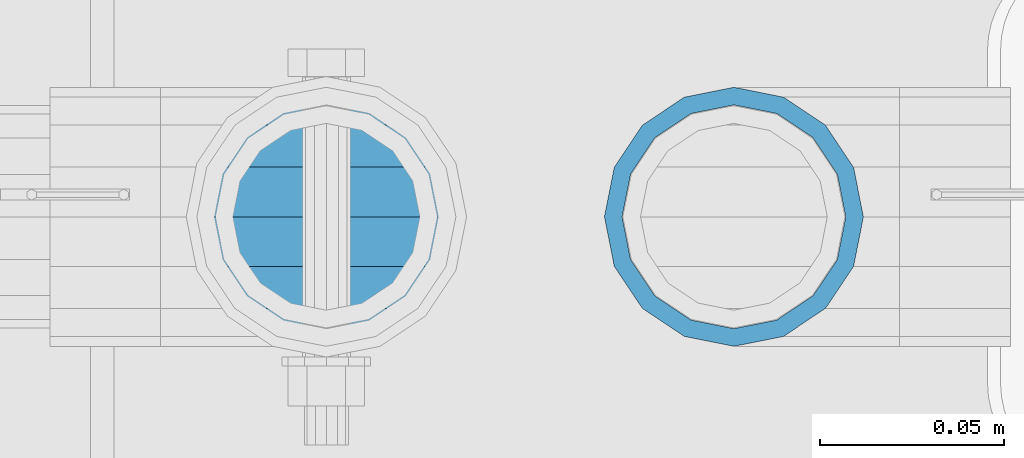
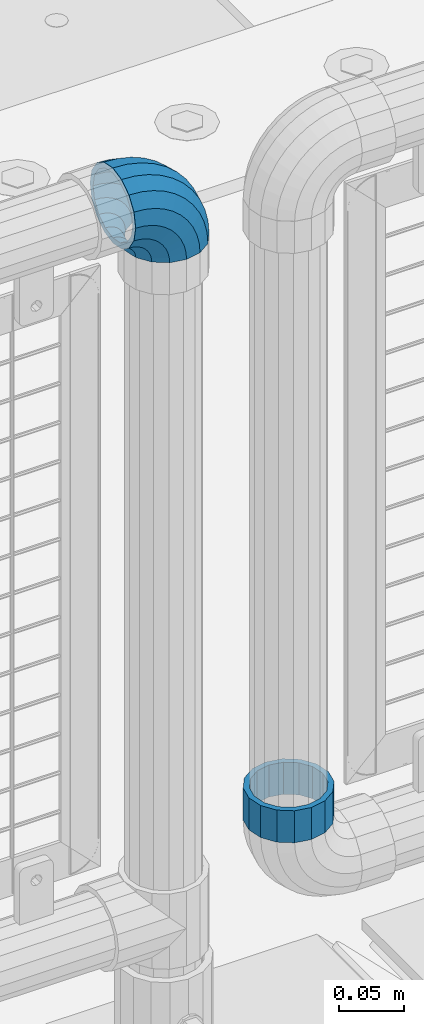
# One storey, part 163 of 242: 1 beam, 1 member.
"""IFC2X3 building model written with IfcOpenShell, lengths in millimetres."""

from ifc_helpers import new_model, si_unit, frame, origin_with_axes, place, context, subcontext, project, spatial, faceted_brep, material, type_object, element, save


model = new_model("IFC2X3")

# Units and contexts
model_context = context("Model", 3, precision=1e-05, world=origin_with_axes())
body_context = subcontext(model_context, "Body", "Model", "MODEL_VIEW")
ifc_project = project(units=[si_unit("LENGTHUNIT", "METRE", prefix="MILLI"), si_unit("AREAUNIT", "SQUARE_METRE"), si_unit("VOLUMEUNIT", "CUBIC_METRE"), si_unit("MASSUNIT", "GRAM", prefix="KILO"), si_unit("TIMEUNIT", "SECOND"), si_unit("PLANEANGLEUNIT", "RADIAN"), si_unit("SOLIDANGLEUNIT", "STERADIAN"), si_unit("THERMODYNAMICTEMPERATUREUNIT", "DEGREE_CELSIUS"), si_unit("LUMINOUSINTENSITYUNIT", "LUMEN")], contexts=[model_context])

# Site, building, storey
site_placement = place(None, origin_with_axes())
site = spatial("IfcSite", under=ifc_project, at=site_placement, CompositionType="ELEMENT")
building_placement = place(site_placement, origin_with_axes())
building = spatial("IfcBuilding", under=site, at=building_placement, Name="Standard", CompositionType="ELEMENT")
storey_placement = place(building_placement, origin_with_axes())
storey = spatial("IfcBuildingStorey", under=building, at=storey_placement, Name="Undefined", CompositionType="ELEMENT", Elevation=0.0)

# Beam
ifc_material = material(Name="Misc_Undefined")
beam_type = type_object("IfcBeamType", PredefinedType="NOTDEFINED")
beam_placement = place(storey_placement, frame((-23755.39, -19335.5, 373.170000000002), z_axis=(-1.0, 0.0, 0.0), x_axis=(0.0, 0.0, -1.0)))
element("IfcBeam", 1, at=beam_placement, inside=storey, type_object=beam_type, material=ifc_material, context=body_context, shape_type="Brep", body=[
    faceted_brep([(0.0, -30.3499999999985, 0.0), (0.0, -28.0397438117179, 11.6144421722784), (30.0, -28.0397438117179, 11.6144421722805), (30.0, -30.3499999999985, 0.0), (0.0, -21.46069080901, 21.4606908090136), (30.0, -21.46069080901, 21.4606908090117), (0.0, -11.614442172282, 28.0397438117143), (30.0, -11.614442172282, 28.0397438117176), (0.0, 0.0, 30.3499999999985), (30.0, 0.0, 30.35), (0.0, 11.614442172282, 28.0397438117143), (30.0, 11.614442172282, 28.0397438117176), (0.0, 21.46069080901, 21.4606908090136), (30.0, 21.46069080901, 21.4606908090117), (0.0, 28.0397438117179, 11.6144421722784), (30.0, 28.0397438117179, 11.6144421722805), (0.0, 30.3499999999985, 0.0), (30.0, 30.3499999999985, 0.0), (0.0, 28.0397438117179, -11.6144421722784), (30.0, 28.0397438117179, -11.6144421722805), (0.0, 21.46069080901, -21.4606908090136), (30.0, 21.46069080901, -21.4606908090117), (0.0, 11.614442172282, -28.0397438117143), (30.0, 11.614442172282, -28.0397438117176), (0.0, 0.0, -30.3499999999985), (30.0, 0.0, -30.35), (0.0, -11.614442172282, -28.0397438117143), (30.0, -11.614442172282, -28.0397438117176), (0.0, -21.46069080901, -21.4606908090136), (30.0, -21.46069080901, -21.4606908090117), (0.0, -28.0397438117179, -11.6144421722784), (30.0, -28.0397438117179, -11.6144421722805), (0.0, -35.1500000000015, 0.0), (0.0, -32.4743655677703, -13.4513226476338), (30.0, -32.4743655677703, -13.4513226476329), (30.0, -35.1500000000015, 0.0), (0.0, -24.8548033587067, -24.8548033587067), (30.0, -24.8548033587067, -24.8548033587072), (0.0, -13.4513226476338, -32.4743655677739), (30.0, -13.4513226476338, -32.4743655677718), (0.0, 0.0, -35.1500000000015), (30.0, 0.0, -35.15), (0.0, 13.4513226476338, -32.4743655677739), (30.0, 13.4513226476338, -32.4743655677718), (0.0, 24.8548033587067, -24.8548033587067), (30.0, 24.8548033587067, -24.8548033587072), (0.0, 32.4743655677703, -13.4513226476338), (30.0, 32.4743655677703, -13.4513226476329), (0.0, 35.1500000000015, 0.0), (30.0, 35.1500000000015, 0.0), (0.0, 32.4743655677703, 13.4513226476338), (30.0, 32.4743655677703, 13.4513226476329), (0.0, 24.8548033587067, 24.8548033587067), (30.0, 24.8548033587067, 24.8548033587072), (0.0, 13.4513226476338, 32.4743655677739), (30.0, 13.4513226476338, 32.4743655677718), (0.0, 0.0, 35.1500000000015), (30.0, 0.0, 35.15), (0.0, -13.4513226476338, 32.4743655677739), (30.0, -13.4513226476338, 32.4743655677718), (0.0, -24.8548033587067, 24.8548033587067), (30.0, -24.8548033587067, 24.8548033587072), (0.0, -32.4743655677703, 13.4513226476338), (30.0, -32.4743655677703, 13.4513226476329)], [[[0, 1, 2, 3]], [[1, 4, 5, 2]], [[4, 6, 7, 5]], [[6, 8, 9, 7]], [[8, 10, 11, 9]], [[10, 12, 13, 11]], [[12, 14, 15, 13]], [[14, 16, 17, 15]], [[16, 18, 19, 17]], [[18, 20, 21, 19]], [[20, 22, 23, 21]], [[22, 24, 25, 23]], [[24, 26, 27, 25]], [[26, 28, 29, 27]], [[28, 30, 31, 29]], [[30, 0, 3, 31]], [[32, 33, 34, 35]], [[33, 36, 37, 34]], [[36, 38, 39, 37]], [[38, 40, 41, 39]], [[40, 42, 43, 41]], [[42, 44, 45, 43]], [[44, 46, 47, 45]], [[46, 48, 49, 47]], [[48, 50, 51, 49]], [[50, 52, 53, 51]], [[52, 54, 55, 53]], [[54, 56, 57, 55]], [[56, 58, 59, 57]], [[58, 60, 61, 59]], [[60, 62, 63, 61]], [[62, 32, 35, 63]], [[37, 39, 41, 43, 45, 47, 49, 51, 53, 55, 57, 59, 61, 63, 35, 34], [5, 7, 9, 11, 13, 15, 17, 19, 21, 23, 25, 27, 29, 31, 3, 2]], [[62, 60, 58, 56, 54, 52, 50, 48, 46, 44, 42, 40, 38, 36, 33, 32], [30, 28, 26, 24, 22, 20, 18, 16, 14, 12, 10, 8, 6, 4, 1, 0]]]),
])

# Member
member_type = type_object("IfcMemberType", PredefinedType="NOTDEFINED")
member_placement = place(storey_placement, frame((-23866.0, -19335.5, 924.85), z_axis=(0.707106781186547, 0.0, 0.707106781186548), x_axis=(-0.707106781186548, 0.0, 0.707106781186548)))
element("IfcMember", 2, at=member_placement, inside=storey, type_object=member_type, material=ifc_material, context=body_context, shape_type="Brep", body=[
    faceted_brep([(0.0, -35.1500000000015, 0.0), (9.51152146006643, -32.4743655677703, -9.51152146006643), (13.2759578763398, -32.4743655677703, -6.29638902527768), (5.36946880023243, -35.1500000000015, 4.58595959347804), (17.5749999999971, -24.8548033587067, -17.5749999999971), (19.978755663109, -24.8548033587067, -15.5219987155633), (22.9628441077002, -13.4513226476338, -22.9628441077002), (24.4574219585229, -13.4513226476338, -21.6863540323939), (24.8548033587067, 0.0, -24.8548033587067), (26.0301204183124, 0.0, -23.8509877588003), (22.9628441077002, 13.4513226476338, -22.9628441077002), (24.4574219585229, 13.4513226476338, -21.6863540323939), (17.5749999999971, 24.8548033587067, -17.5749999999971), (19.978755663109, 24.8548033587067, -15.5219987155633), (9.51152146006643, 32.4743655677703, -9.51152146006643), (13.2759578763398, 32.4743655677703, -6.29638902527768), (0.0, 35.1500000000015, 0.0), (5.36946880023243, 35.1500000000015, 4.58595959347804), (-9.51152146007371, 32.4743655677703, 9.51152146007371), (-2.53702027587133, 32.4743655677703, 15.4683082122338), (-17.5750000000007, 24.8548033587067, 17.5750000000007), (-9.23981806264783, 24.8548033587067, 24.6939179025212), (-22.9628441077039, 13.4513226476338, 22.9628441077039), (-13.718484358058, 13.4513226476338, 30.8582732193499), (-24.8548033587103, 0.0, 24.8548033587103), (-15.2911828178512, 0.0, 33.02290694576), (-22.9628441077039, -13.4513226476338, 22.9628441077039), (-13.718484358058, -13.4513226476338, 30.8582732193499), (-17.5750000000007, -24.8548033587067, 17.5750000000007), (-9.23981806264783, -24.8548033587067, 24.6939179025212), (-9.51152146007371, -32.4743655677703, 9.51152146007371), (-2.53702027587133, -32.4743655677703, 15.4683082122338), (0.0, -30.3499999999985, 0.0), (-8.2126508197216, -28.0397438117179, 8.2126508197216), (-1.45732902223972, -28.0397438117179, 13.9822406910389), (5.36946880023243, -30.3499999999985, 4.58595959347804), (-15.1749999999993, -21.46069080901, 15.1750000000029), (-7.24480876131565, -21.46069080901, 21.9480231689959), (-19.827092992, -11.614442172282, 19.827092992), (-11.1118790903529, -11.614442172282, 27.2705888550809), (-21.4606908090136, 0.0, 21.4606908090136), (-12.4698136068437, 0.0, 29.1396253727598), (-19.827092992, 11.614442172282, 19.827092992), (-11.1118790903529, 11.614442172282, 27.2705888550809), (-15.1749999999993, 21.46069080901, 15.1750000000029), (-7.24480876131565, 21.46069080901, 21.9480231689959), (-8.2126508197216, 28.0397438117179, 8.2126508197216), (-1.45732902223972, 28.0397438117179, 13.9822406910389), (0.0, 30.3499999999985, 0.0), (5.36946880023243, 30.3499999999985, 4.58595959347804), (8.21265081971796, 28.0397438117179, -8.21265081971796), (12.1962666227009, 28.0397438117179, -4.81032150407918), (15.1749999999956, 21.46069080901, -15.1749999999956), (17.9837463617769, 21.46069080901, -12.776103982038), (19.8270929919963, 11.614442172282, -19.8270929919963), (21.8508166908177, 11.614442172282, -18.0986696681193), (21.46069080901, 0.0, -21.46069080901), (23.2087512073085, 0.0, -19.9677061858001), (19.8270929919963, -11.614442172282, -19.8270929919963), (21.8508166908177, -11.614442172282, -18.0986696681193), (15.1749999999956, -21.46069080901, -15.1749999999956), (17.9837463617769, -21.46069080901, -12.776103982038), (8.21265081971796, -28.0397438117179, -8.21265081971796), (12.1962666227009, -28.0397438117179, -4.81032150407918), (17.4970053560683, -32.4743655677703, -3.70972780291959), (11.3902326651114, -35.1500000000015, 8.27548843508339), (22.6740772628618, -24.8548033587067, -13.870303514941), (26.1332861179508, -13.4513226476338, -20.6593831546816), (27.3479987309584, 0.0, -23.0433908901377), (26.1332861179508, 13.4513226476338, -20.6593831546816), (22.6740772628618, 24.8548033587067, -13.870303514941), (17.4970053560683, 32.4743655677703, -3.70972780291959), (11.3902326651114, 35.1500000000015, 8.27548843508339), (5.28345997415818, 32.4743655677703, 20.2607046730864), (0.106388067368243, 24.8548033587067, 30.4212803851133), (-3.35282078772798, 13.4513226476338, 37.2103600248483), (-4.56753340073192, 0.0, 39.5943677603045), (-3.35282078772798, -13.4513226476338, 37.2103600248483), (0.106388067368243, -24.8548033587067, 30.4212803851133), (5.28345997415818, -32.4743655677703, 20.2607046730864), (6.11738625912403, -28.0397438117179, 18.6240321853948), (11.3902326651114, -30.3499999999985, 8.27548843508339), (1.6472829199738, -21.46069080901, 27.3971039595017), (-1.3395446405375, -11.614442172282, 33.2590831078942), (-2.38837900198268, 0.0, 35.3175364441995), (-1.3395446405375, 11.614442172282, 33.2590831078942), (1.6472829199738, 21.46069080901, 27.3971039595017), (6.11738625912403, 28.0397438117179, 18.6240321853948), (11.3902326651114, 30.3499999999985, 8.27548843508339), (16.6630790711024, 28.0397438117179, -2.07305531522434), (21.1331824102526, 21.46069080901, -10.8461270893331), (24.1200099707639, 11.614442172282, -16.7081062377274), (25.1688443322091, 0.0, -18.7665595740364), (24.1200099707639, -11.614442172282, -16.7081062377274), (21.1331824102526, -21.46069080901, -10.8461270893331), (16.6630790711024, -28.0397438117179, -2.07305531522434), (22.070727701459, -32.4743655677703, -1.81522997692991), (17.9140404065183, -35.1500000000015, 10.9777380798896), (25.5945970362081, -24.8548033587067, -12.6605846156453), (27.9491712485069, -13.4513226476338, -19.9072189058916), (28.7759877587996, 0.0, -22.4518984678853), (27.9491712485069, 13.4513226476338, -19.9072189058916), (25.5945970362081, 24.8548033587067, -12.6605846156453), (22.070727701459, 32.4743655677703, -1.81522997692991), (17.9140404065183, 35.1500000000015, 10.9777380798896), (13.7573531115813, 32.4743655677703, 23.7707061367073), (10.2334837768321, 24.8548033587067, 34.6160607754227), (7.87890956453339, 13.4513226476338, 41.862695065669), (7.05209305424069, 0.0, 44.4073746276626), (7.87890956453339, -13.4513226476338, 41.862695065669), (10.2334837768321, -24.8548033587067, 34.6160607754227), (13.7573531115813, -32.4743655677703, 23.7707061367073), (14.3249803951003, -28.0397438117179, 22.0237289909674), (17.9140404065183, -30.3499999999985, 10.9777380798896), (11.2823222355109, -21.46069080901, 31.3880679179947), (9.24928305077992, -11.614442172282, 37.6451191472697), (8.53537462723762, 0.0, 39.8423033494473), (9.24928305077992, 11.614442172282, 37.6451191472697), (11.2823222355109, 21.46069080901, 31.3880679179947), (14.3249803951003, 28.0397438117179, 22.0237289909674), (17.9140404065183, 30.3499999999985, 10.9777380798896), (21.50310041794, 28.0397438117179, -0.0682528311899659), (24.5457585775293, 21.46069080901, -9.43259175821731), (26.5787977622604, 11.614442172282, -15.6896429874923), (27.2927061858027, 0.0, -17.8868271896699), (26.5787977622604, -11.614442172282, -15.6896429874923), (24.5457585775293, -21.46069080901, -9.43259175821731), (21.50310041794, -28.0397438117179, -0.0682528311899659), (26.8845046890456, -32.4743655677703, -0.659544371261291), (24.7802542265854, -35.1500000000015, 12.6261701733874), (28.6684020936846, -24.8548033587067, -11.9226293117918), (29.8603642316994, -13.4513226476338, -19.4483820661244), (30.2789256727447, 0.0, -22.0910749985305), (29.8603642316994, 13.4513226476338, -19.4483820661244), (28.6684020936846, 24.8548033587067, -11.9226293117918), (26.8845046890456, 32.4743655677703, -0.659544371261291), (24.7802542265854, 35.1500000000015, 12.6261701733874), (22.6760037641179, 32.4743655677703, 25.911884718038), (20.8921063594826, 24.8548033587067, 37.1749696585684), (19.7001442214641, 13.4513226476338, 44.7007224129011), (19.2815827804188, 0.0, 47.3434153453072), (19.7001442214641, -13.4513226476338, 44.7007224129011), (20.8921063594826, -24.8548033587067, 37.1749696585684), (22.6760037641179, -32.4743655677703, 25.911884718038), (22.963355178621, -28.0397438117179, 24.0976192894668), (24.7802542265854, -30.3499999999985, 12.6261701733874), (21.4230625404816, -21.46069080901, 33.8226442665673), (20.3938719035323, -11.614442172282, 40.3206982094944), (20.032468212612, 0.0, 42.6025113104497), (20.3938719035323, 11.614442172282, 40.3206982094944), (21.4230625404816, 21.46069080901, 33.8226442665673), (22.963355178621, 28.0397438117179, 24.0976192894668), (24.7802542265854, 30.3499999999985, 12.6261701733874), (26.5971532745461, 28.0397438117179, 1.15472105730987), (28.1374459126855, 21.46069080901, -8.5703039197906), (29.1666365496349, 11.614442172282, -15.0683578627177), (29.5280402405515, 0.0, -17.350170963673), (29.1666365496349, -11.614442172282, -15.0683578627177), (28.1374459126855, -21.46069080901, -8.5703039197906), (26.5971532745461, -28.0397438117179, 1.15472105730987), (31.8198051533909, -32.4743655677703, -0.271127801024704), (31.8198051533909, -35.1500000000015, 13.1801948466091), (31.8198051533946, -24.8548033587067, -11.6746085121031), (31.8198051533909, -13.4513226476338, -19.2941707211648), (31.8198051533909, 0.0, -21.9698051533924), (31.8198051533909, 13.4513226476338, -19.2941707211648), (31.8198051533946, 24.8548033587067, -11.6746085121031), (31.8198051533909, 32.4743655677703, -0.271127801024704), (31.8198051533909, 35.1500000000015, 13.1801948466091), (31.8198051533909, 32.4743655677703, 26.6315174942411), (31.8198051533909, 24.8548033587067, 38.0349982053158), (31.8198051533909, 13.4513226476338, 45.6545604143812), (31.8198051533946, 0.0, 48.3301948466051), (31.8198051533909, -13.4513226476338, 45.6545604143812), (31.8198051533909, -24.8548033587067, 38.0349982053158), (31.8198051533909, -32.4743655677703, 26.6315174942411), (31.8198051533909, -28.0397438117179, 24.7946370188874), (31.8198051533909, -30.3499999999985, 13.1801948466091), (31.8198051533946, -21.46069080901, 34.6408856556172), (31.8198051533946, -11.614442172282, 41.2199386583234), (31.8198051533909, 0.0, 43.5301948466076), (31.8198051533946, 11.614442172282, 41.2199386583234), (31.8198051533946, 21.46069080901, 34.6408856556172), (31.8198051533909, 28.0397438117179, 24.7946370188874), (31.8198051533909, 30.3499999999985, 13.1801948466091), (31.8198051533946, 28.0397438117179, 1.56575267432527), (31.8198051533909, 21.46069080901, -8.28049596240453), (31.8198051533946, 11.614442172282, -14.8595489651107), (31.8198051533909, 0.0, -17.1698051533913), (31.8198051533946, -11.614442172282, -14.8595489651107), (31.8198051533909, -21.46069080901, -8.28049596240453), (31.8198051533946, -28.0397438117179, 1.56575267432527), (36.7551056177363, -32.4743655677703, -0.659544371261291), (38.8593560802037, -35.1500000000015, 12.6261701733874), (34.9712082131009, -24.8548033587067, -11.9226293117899), (33.7792460750898, -13.4513226476338, -19.4483820661244), (33.3606846340372, 0.0, -22.0910749985305), (33.7792460750898, 13.4513226476338, -19.4483820661244), (34.9712082131009, 24.8548033587067, -11.9226293117899), (36.7551056177363, 32.4743655677703, -0.659544371261291), (38.8593560802037, 35.1500000000015, 12.6261701733874), (40.9636065426712, 32.4743655677703, 25.911884718038), (42.7475039473029, 24.8548033587067, 37.1749696585703), (43.9394660853177, 13.4513226476338, 44.7007224129011), (44.3580275263666, 0.0, 47.3434153453054), (43.9394660853177, -13.4513226476338, 44.7007224129011), (42.7475039473029, -24.8548033587067, 37.1749696585703), (40.9636065426712, -32.4743655677703, 25.911884718038), (40.6762551281645, -28.0397438117179, 24.097619289465), (38.8593560802037, -30.3499999999985, 12.6261701733874), (42.2165477663038, -21.46069080901, 33.8226442665655), (43.2457384032568, -11.614442172282, 40.3206982094944), (43.6071420941771, 0.0, 42.6025113104533), (43.2457384032568, 11.614442172282, 40.3206982094944), (42.2165477663038, 21.46069080901, 33.8226442665655), (40.6762551281645, 28.0397438117179, 24.097619289465), (38.8593560802037, 30.3499999999985, 12.6261701733874), (37.042457032243, 28.0397438117179, 1.15472105730987), (35.5021643941, 21.46069080901, -8.5703039197906), (34.4729737571543, 11.614442172282, -15.0683578627231), (34.1115700662303, 0.0, -17.350170963673), (34.4729737571543, -11.614442172282, -15.0683578627231), (35.5021643941, -21.46069080901, -8.5703039197906), (37.042457032243, -28.0397438117179, 1.15472105730987), (41.5688826053265, -32.4743655677703, -1.81522997693173), (45.7255699002671, -35.1500000000015, 10.9777380798896), (38.0450132705773, -24.8548033587067, -12.6605846156435), (35.6904390582749, -13.4513226476338, -19.9072189058897), (34.8636225479822, 0.0, -22.4518984678834), (35.6904390582749, 13.4513226476338, -19.9072189058897), (38.0450132705773, 24.8548033587067, -12.6605846156435), (41.5688826053265, 32.4743655677703, -1.81522997693173), (45.7255699002671, 35.1500000000015, 10.9777380798896), (49.8822571952041, 32.4743655677703, 23.7707061367091), (53.4061265299533, 24.8548033587067, 34.6160607754209), (55.7607007422557, 13.4513226476338, 41.8626950656671), (56.5875172525448, 0.0, 44.4073746276645), (55.7607007422557, -13.4513226476338, 41.8626950656671), (53.4061265299533, -24.8548033587067, 34.6160607754209), (49.8822571952041, -32.4743655677703, 23.7707061367091), (49.3146299116852, -28.0397438117179, 22.0237289909692), (45.7255699002671, -30.3499999999985, 10.9777380798896), (52.3572880712782, -21.46069080901, 31.3880679179947), (54.3903272560092, -11.614442172282, 37.6451191472679), (55.1042356795442, 0.0, 39.8423033494473), (54.3903272560092, 11.614442172282, 37.6451191472679), (52.3572880712782, 21.46069080901, 31.3880679179947), (49.3146299116852, 28.0397438117179, 22.0237289909692), (45.7255699002671, 30.3499999999985, 10.9777380798896), (42.1365098888455, 28.0397438117179, -0.0682528311917849), (39.0938517292525, 21.46069080901, -9.43259175821731), (37.0608125445215, 11.614442172282, -15.6896429874905), (36.3469041209864, 0.0, -17.8868271896699), (37.0608125445215, -11.614442172282, -15.6896429874905), (39.0938517292525, -21.46069080901, -9.43259175821731), (42.1365098888455, -28.0397438117179, -0.0682528311917849), (46.1426049507172, -32.4743655677703, -3.70972780292141), (52.2493776416704, -35.1500000000015, 8.27548843508339), (40.9655330439236, -24.8548033587067, -13.8703035149429), (37.5063241888347, -13.4513226476338, -20.6593831546797), (36.2916115758235, 0.0, -23.0433908901359), (37.5063241888347, 13.4513226476338, -20.6593831546797), (40.9655330439236, 24.8548033587067, -13.8703035149429), (46.1426049507172, 32.4743655677703, -3.70972780292141), (52.2493776416704, 35.1500000000015, 8.27548843508339), (58.3561503326309, 32.4743655677703, 20.26070467309), (63.5332222394209, 24.8548033587067, 30.4212803851133), (66.9924310945098, 13.4513226476338, 37.2103600248465), (68.2071437075174, 0.0, 39.5943677603027), (66.9924310945098, -13.4513226476338, 37.2103600248465), (63.5332222394209, -24.8548033587067, 30.4212803851133), (58.3561503326309, -32.4743655677703, 20.26070467309), (57.5222240476614, -28.0397438117179, 18.6240321853948), (52.2493776416704, -30.3499999999985, 8.27548843508339), (61.9923273868117, -21.46069080901, 27.3971039595035), (64.9791549473193, -11.614442172282, 33.259083107896), (66.0279893087682, 0.0, 35.3175364442013), (64.9791549473193, 11.614442172282, 33.259083107896), (61.9923273868117, 21.46069080901, 27.3971039595035), (57.5222240476614, 28.0397438117179, 18.6240321853948), (52.2493776416704, 30.3499999999985, 8.27548843508339), (46.9765312356831, 28.0397438117179, -2.07305531522616), (42.5064278965328, 21.46069080901, -10.8461270893349), (39.5196003360215, 11.614442172282, -16.7081062377292), (38.4707659745764, 0.0, -18.7665595740327), (39.5196003360215, -11.614442172282, -16.7081062377292), (42.5064278965328, -21.46069080901, -10.8461270893349), (46.9765312356831, -28.0397438117179, -2.07305531522616), (50.3636524304493, -32.4743655677703, -6.29638902527404), (58.2701415065567, -35.1500000000015, 4.58595959347986), (43.6608546436801, -24.8548033587067, -15.5219987155633), (39.1821883482626, -13.4513226476338, -21.686354032392), (37.609489888473, 0.0, -23.8509877587985), (39.1821883482626, 13.4513226476338, -21.686354032392), (43.6608546436801, 24.8548033587067, -15.5219987155633), (50.3636524304493, 32.4743655677703, -6.29638902527404), (58.2701415065567, 35.1500000000015, 4.58595959347986), (66.1766305826604, 32.4743655677703, 15.4683082122356), (72.8794283694297, 24.8548033587067, 24.6939179025212), (77.3580946648435, 13.4513226476338, 30.8582732193518), (78.9307931246331, 0.0, 33.02290694576), (77.3580946648435, -13.4513226476338, 30.8582732193518), (72.8794283694297, -24.8548033587067, 24.6939179025212), (66.1766305826604, -32.4743655677703, 15.4683082122356), (65.0969393290252, -28.0397438117179, 13.9822406910407), (58.2701415065567, -30.3499999999985, 4.58595959347986), (70.8844190681011, -21.46069080901, 21.9480231689959), (74.751489397142, -11.614442172282, 27.270588855079), (76.1094239136328, 0.0, 29.139625372758), (74.751489397142, 11.614442172282, 27.270588855079), (70.8844190681011, 21.46069080901, 21.9480231689959), (65.0969393290252, 28.0397438117179, 13.9822406910407), (58.2701415065567, 30.3499999999985, 4.58595959347986), (51.4433436840845, 28.0397438117179, -4.81032150407918), (45.655863945005, 21.46069080901, -12.7761039820361), (41.7887936159677, 11.614442172282, -18.0986696681175), (40.4308590994769, 0.0, -19.9677061858019), (41.7887936159677, -11.614442172282, -18.0986696681175), (45.655863945005, -21.46069080901, -12.7761039820361), (51.4433436840845, -28.0397438117179, -4.81032150407918), (54.1280888467154, -32.4743655677703, -9.51152146006643), (63.6396103067855, -35.1500000000015, 3.63797880709171e-12), (46.0646103067847, -24.8548033587067, -17.5749999999971), (40.6767661990853, -13.4513226476338, -22.9628441077002), (38.7848069480788, 0.0, -24.8548033587049), (40.6767661990853, 13.4513226476338, -22.9628441077002), (46.0646103067847, 24.8548033587067, -17.5749999999971), (54.1280888467154, 32.4743655677703, -9.51152146006643), (63.6396103067855, 35.1500000000015, 3.63797880709171e-12), (73.1511317668555, 32.4743655677703, 9.51152146007189), (81.2146103067862, 24.8548033587067, 17.5750000000025), (86.6024544144893, 13.4513226476338, 22.9628441077057), (88.4944136654922, 0.0, 24.8548033587103), (86.6024544144893, -13.4513226476338, 22.9628441077057), (81.2146103067862, -24.8548033587067, 17.5750000000025), (73.1511317668555, -32.4743655677703, 9.51152146007189), (71.8522611265034, -28.0397438117179, 8.2126508197216), (63.6396103067855, -30.3499999999985, 3.63797880709171e-12), (78.8146103067847, -21.46069080901, 15.1750000000029), (83.4667032987854, -11.614442172282, 19.8270929920018), (85.1003011157991, 0.0, 21.4606908090154), (83.4667032987854, 11.614442172282, 19.8270929920018), (78.8146103067847, 21.46069080901, 15.1750000000029), (71.8522611265034, 28.0397438117179, 8.2126508197216), (63.6396103067855, 30.3499999999985, 3.63797880709171e-12), (55.4269594870675, 28.0397438117179, -8.21265081971615), (48.4646103067862, 21.46069080901, -15.1749999999975), (43.8125173147855, 11.614442172282, -19.8270929919963), (42.1789194977755, 0.0, -21.4606908090082), (43.8125173147855, -11.614442172282, -19.8270929919963), (48.4646103067862, -21.46069080901, -15.1749999999975), (55.4269594870675, -28.0397438117179, -8.21265081971615)], [[[0, 1, 2, 3]], [[1, 4, 5, 2]], [[4, 6, 7, 5]], [[6, 8, 9, 7]], [[8, 10, 11, 9]], [[10, 12, 13, 11]], [[12, 14, 15, 13]], [[14, 16, 17, 15]], [[16, 18, 19, 17]], [[18, 20, 21, 19]], [[20, 22, 23, 21]], [[22, 24, 25, 23]], [[24, 26, 27, 25]], [[26, 28, 29, 27]], [[28, 30, 31, 29]], [[30, 0, 3, 31]], [[32, 33, 34, 35]], [[33, 36, 37, 34]], [[36, 38, 39, 37]], [[38, 40, 41, 39]], [[40, 42, 43, 41]], [[42, 44, 45, 43]], [[44, 46, 47, 45]], [[46, 48, 49, 47]], [[48, 50, 51, 49]], [[50, 52, 53, 51]], [[52, 54, 55, 53]], [[54, 56, 57, 55]], [[56, 58, 59, 57]], [[58, 60, 61, 59]], [[60, 62, 63, 61]], [[62, 32, 35, 63]], [[30, 28, 26, 24, 22, 20, 18, 16, 14, 12, 10, 8, 6, 4, 1, 0], [62, 60, 58, 56, 54, 52, 50, 48, 46, 44, 42, 40, 38, 36, 33, 32]], [[3, 2, 64, 65]], [[2, 5, 66, 64]], [[5, 7, 67, 66]], [[7, 9, 68, 67]], [[9, 11, 69, 68]], [[11, 13, 70, 69]], [[13, 15, 71, 70]], [[15, 17, 72, 71]], [[17, 19, 73, 72]], [[19, 21, 74, 73]], [[21, 23, 75, 74]], [[23, 25, 76, 75]], [[25, 27, 77, 76]], [[27, 29, 78, 77]], [[29, 31, 79, 78]], [[31, 3, 65, 79]], [[35, 34, 80, 81]], [[34, 37, 82, 80]], [[37, 39, 83, 82]], [[39, 41, 84, 83]], [[41, 43, 85, 84]], [[43, 45, 86, 85]], [[45, 47, 87, 86]], [[47, 49, 88, 87]], [[49, 51, 89, 88]], [[51, 53, 90, 89]], [[53, 55, 91, 90]], [[55, 57, 92, 91]], [[57, 59, 93, 92]], [[59, 61, 94, 93]], [[61, 63, 95, 94]], [[63, 35, 81, 95]], [[65, 64, 96, 97]], [[64, 66, 98, 96]], [[66, 67, 99, 98]], [[67, 68, 100, 99]], [[68, 69, 101, 100]], [[69, 70, 102, 101]], [[70, 71, 103, 102]], [[71, 72, 104, 103]], [[72, 73, 105, 104]], [[73, 74, 106, 105]], [[74, 75, 107, 106]], [[75, 76, 108, 107]], [[76, 77, 109, 108]], [[77, 78, 110, 109]], [[78, 79, 111, 110]], [[79, 65, 97, 111]], [[81, 80, 112, 113]], [[80, 82, 114, 112]], [[82, 83, 115, 114]], [[83, 84, 116, 115]], [[84, 85, 117, 116]], [[85, 86, 118, 117]], [[86, 87, 119, 118]], [[87, 88, 120, 119]], [[88, 89, 121, 120]], [[89, 90, 122, 121]], [[90, 91, 123, 122]], [[91, 92, 124, 123]], [[92, 93, 125, 124]], [[93, 94, 126, 125]], [[94, 95, 127, 126]], [[95, 81, 113, 127]], [[97, 96, 128, 129]], [[96, 98, 130, 128]], [[98, 99, 131, 130]], [[99, 100, 132, 131]], [[100, 101, 133, 132]], [[101, 102, 134, 133]], [[102, 103, 135, 134]], [[103, 104, 136, 135]], [[104, 105, 137, 136]], [[105, 106, 138, 137]], [[106, 107, 139, 138]], [[107, 108, 140, 139]], [[108, 109, 141, 140]], [[109, 110, 142, 141]], [[110, 111, 143, 142]], [[111, 97, 129, 143]], [[113, 112, 144, 145]], [[112, 114, 146, 144]], [[114, 115, 147, 146]], [[115, 116, 148, 147]], [[116, 117, 149, 148]], [[117, 118, 150, 149]], [[118, 119, 151, 150]], [[119, 120, 152, 151]], [[120, 121, 153, 152]], [[121, 122, 154, 153]], [[122, 123, 155, 154]], [[123, 124, 156, 155]], [[124, 125, 157, 156]], [[125, 126, 158, 157]], [[126, 127, 159, 158]], [[127, 113, 145, 159]], [[129, 128, 160, 161]], [[128, 130, 162, 160]], [[130, 131, 163, 162]], [[131, 132, 164, 163]], [[132, 133, 165, 164]], [[133, 134, 166, 165]], [[134, 135, 167, 166]], [[135, 136, 168, 167]], [[136, 137, 169, 168]], [[137, 138, 170, 169]], [[138, 139, 171, 170]], [[139, 140, 172, 171]], [[140, 141, 173, 172]], [[141, 142, 174, 173]], [[142, 143, 175, 174]], [[143, 129, 161, 175]], [[145, 144, 176, 177]], [[144, 146, 178, 176]], [[146, 147, 179, 178]], [[147, 148, 180, 179]], [[148, 149, 181, 180]], [[149, 150, 182, 181]], [[150, 151, 183, 182]], [[151, 152, 184, 183]], [[152, 153, 185, 184]], [[153, 154, 186, 185]], [[154, 155, 187, 186]], [[155, 156, 188, 187]], [[156, 157, 189, 188]], [[157, 158, 190, 189]], [[158, 159, 191, 190]], [[159, 145, 177, 191]], [[161, 160, 192, 193]], [[160, 162, 194, 192]], [[162, 163, 195, 194]], [[163, 164, 196, 195]], [[164, 165, 197, 196]], [[165, 166, 198, 197]], [[166, 167, 199, 198]], [[167, 168, 200, 199]], [[168, 169, 201, 200]], [[169, 170, 202, 201]], [[170, 171, 203, 202]], [[171, 172, 204, 203]], [[172, 173, 205, 204]], [[173, 174, 206, 205]], [[174, 175, 207, 206]], [[175, 161, 193, 207]], [[177, 176, 208, 209]], [[176, 178, 210, 208]], [[178, 179, 211, 210]], [[179, 180, 212, 211]], [[180, 181, 213, 212]], [[181, 182, 214, 213]], [[182, 183, 215, 214]], [[183, 184, 216, 215]], [[184, 185, 217, 216]], [[185, 186, 218, 217]], [[186, 187, 219, 218]], [[187, 188, 220, 219]], [[188, 189, 221, 220]], [[189, 190, 222, 221]], [[190, 191, 223, 222]], [[191, 177, 209, 223]], [[193, 192, 224, 225]], [[192, 194, 226, 224]], [[194, 195, 227, 226]], [[195, 196, 228, 227]], [[196, 197, 229, 228]], [[197, 198, 230, 229]], [[198, 199, 231, 230]], [[199, 200, 232, 231]], [[200, 201, 233, 232]], [[201, 202, 234, 233]], [[202, 203, 235, 234]], [[203, 204, 236, 235]], [[204, 205, 237, 236]], [[205, 206, 238, 237]], [[206, 207, 239, 238]], [[207, 193, 225, 239]], [[209, 208, 240, 241]], [[208, 210, 242, 240]], [[210, 211, 243, 242]], [[211, 212, 244, 243]], [[212, 213, 245, 244]], [[213, 214, 246, 245]], [[214, 215, 247, 246]], [[215, 216, 248, 247]], [[216, 217, 249, 248]], [[217, 218, 250, 249]], [[218, 219, 251, 250]], [[219, 220, 252, 251]], [[220, 221, 253, 252]], [[221, 222, 254, 253]], [[222, 223, 255, 254]], [[223, 209, 241, 255]], [[225, 224, 256, 257]], [[224, 226, 258, 256]], [[226, 227, 259, 258]], [[227, 228, 260, 259]], [[228, 229, 261, 260]], [[229, 230, 262, 261]], [[230, 231, 263, 262]], [[231, 232, 264, 263]], [[232, 233, 265, 264]], [[233, 234, 266, 265]], [[234, 235, 267, 266]], [[235, 236, 268, 267]], [[236, 237, 269, 268]], [[237, 238, 270, 269]], [[238, 239, 271, 270]], [[239, 225, 257, 271]], [[241, 240, 272, 273]], [[240, 242, 274, 272]], [[242, 243, 275, 274]], [[243, 244, 276, 275]], [[244, 245, 277, 276]], [[245, 246, 278, 277]], [[246, 247, 279, 278]], [[247, 248, 280, 279]], [[248, 249, 281, 280]], [[249, 250, 282, 281]], [[250, 251, 283, 282]], [[251, 252, 284, 283]], [[252, 253, 285, 284]], [[253, 254, 286, 285]], [[254, 255, 287, 286]], [[255, 241, 273, 287]], [[257, 256, 288, 289]], [[256, 258, 290, 288]], [[258, 259, 291, 290]], [[259, 260, 292, 291]], [[260, 261, 293, 292]], [[261, 262, 294, 293]], [[262, 263, 295, 294]], [[263, 264, 296, 295]], [[264, 265, 297, 296]], [[265, 266, 298, 297]], [[266, 267, 299, 298]], [[267, 268, 300, 299]], [[268, 269, 301, 300]], [[269, 270, 302, 301]], [[270, 271, 303, 302]], [[271, 257, 289, 303]], [[273, 272, 304, 305]], [[272, 274, 306, 304]], [[274, 275, 307, 306]], [[275, 276, 308, 307]], [[276, 277, 309, 308]], [[277, 278, 310, 309]], [[278, 279, 311, 310]], [[279, 280, 312, 311]], [[280, 281, 313, 312]], [[281, 282, 314, 313]], [[282, 283, 315, 314]], [[283, 284, 316, 315]], [[284, 285, 317, 316]], [[285, 286, 318, 317]], [[286, 287, 319, 318]], [[287, 273, 305, 319]], [[289, 288, 320, 321]], [[288, 290, 322, 320]], [[290, 291, 323, 322]], [[291, 292, 324, 323]], [[292, 293, 325, 324]], [[293, 294, 326, 325]], [[294, 295, 327, 326]], [[295, 296, 328, 327]], [[296, 297, 329, 328]], [[297, 298, 330, 329]], [[298, 299, 331, 330]], [[299, 300, 332, 331]], [[300, 301, 333, 332]], [[301, 302, 334, 333]], [[302, 303, 335, 334]], [[303, 289, 321, 335]], [[305, 304, 336, 337]], [[304, 306, 338, 336]], [[306, 307, 339, 338]], [[307, 308, 340, 339]], [[308, 309, 341, 340]], [[309, 310, 342, 341]], [[310, 311, 343, 342]], [[311, 312, 344, 343]], [[312, 313, 345, 344]], [[313, 314, 346, 345]], [[314, 315, 347, 346]], [[315, 316, 348, 347]], [[316, 317, 349, 348]], [[317, 318, 350, 349]], [[318, 319, 351, 350]], [[319, 305, 337, 351]], [[322, 323, 324, 325, 326, 327, 328, 329, 330, 331, 332, 333, 334, 335, 321, 320], [338, 339, 340, 341, 342, 343, 344, 345, 346, 347, 348, 349, 350, 351, 337, 336]]]),
])

save(model, "model.ifc")
